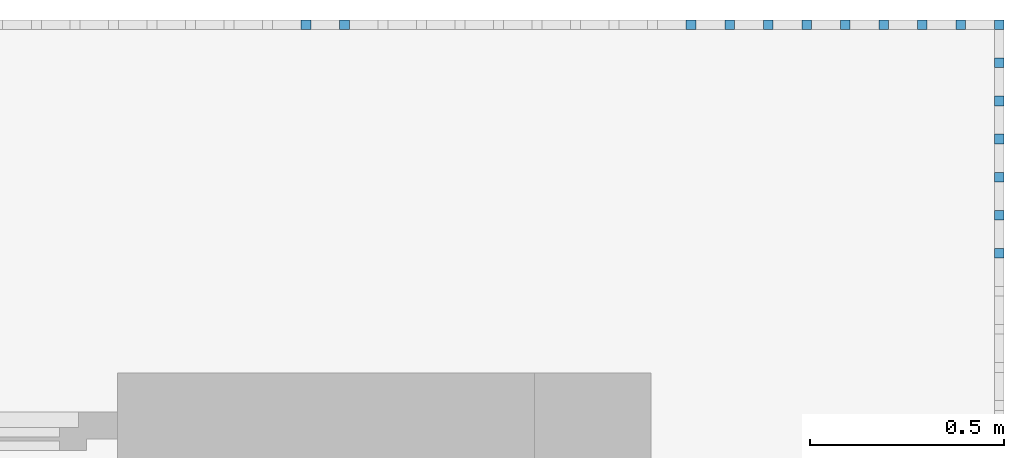
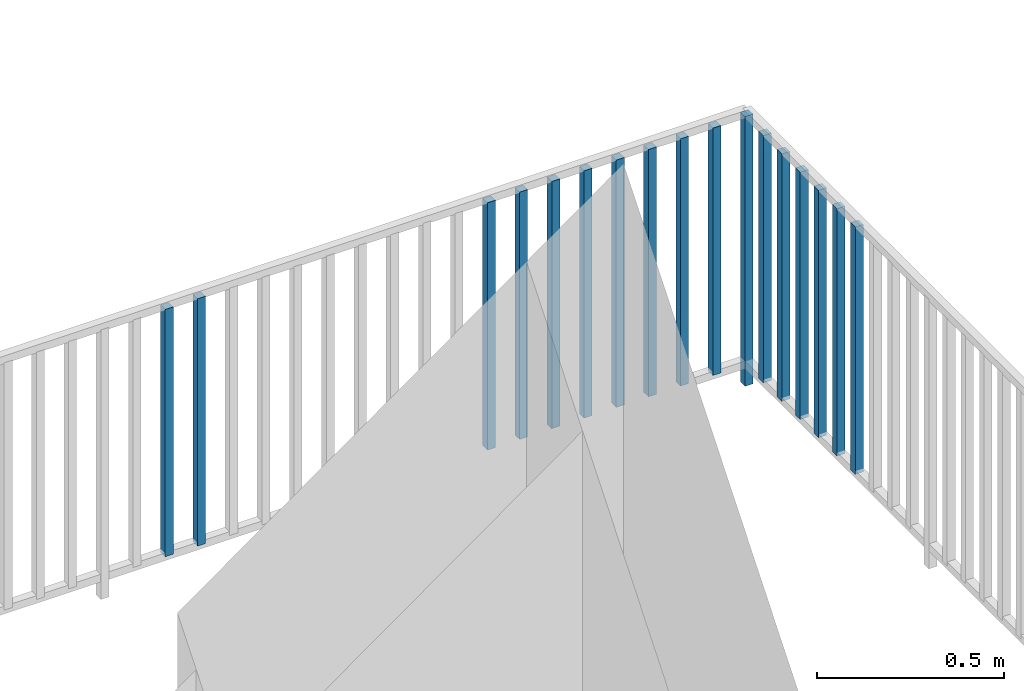
# One storey, part 54 of 54: 18 building element parts, 1 element without a shape of its own.
"""IFC4 building model written with IfcOpenShell, lengths in metres."""

from ifc_helpers import new_model, entity, si_unit, converted_unit, derived_unit, direction, frame, origin_with_axes, place, context, subcontext, project, spatial, polygons, material, type_object, element, aggregate, save


model = new_model("IFC4")

# Units and contexts
model_context = context("Model", 3, precision=1e-05, world=origin_with_axes(), true_north=direction((0.0, 1.0)))
body_context = subcontext(model_context, "Body", "Model", "MODEL_VIEW")
ifc_project = project(units=[si_unit("LENGTHUNIT", "METRE"), si_unit("AREAUNIT", "SQUARE_METRE"), si_unit("VOLUMEUNIT", "CUBIC_METRE"), converted_unit("PLANEANGLEUNIT", "DEGREE", entity("IfcPlaneAngleMeasure", 0.0174532925199), si_unit("PLANEANGLEUNIT", "RADIAN"), dimensions=[0, 0, 0, 0, 0, 0, 0]), converted_unit("TIMEUNIT", "Year", entity("IfcTimeMeasure", 31556926.0), si_unit("TIMEUNIT", "SECOND"), dimensions=[0, 0, 1, 0, 0, 0, 0]), si_unit("MASSUNIT", "GRAM", prefix="KILO"), si_unit("THERMODYNAMICTEMPERATUREUNIT", "DEGREE_CELSIUS"), si_unit("LUMINOUSINTENSITYUNIT", "LUMEN"), si_unit("ENERGYUNIT", "JOULE", prefix="MEGA"), derived_unit("THERMALCONDUCTANCEUNIT", [(si_unit("POWERUNIT", "WATT"), 1), (si_unit("LENGTHUNIT", "METRE"), -1), (si_unit("THERMODYNAMICTEMPERATUREUNIT", "KELVIN"), -1)]), derived_unit("SPECIFICHEATCAPACITYUNIT", [(si_unit("ENERGYUNIT", "JOULE"), 1), (si_unit("MASSUNIT", "GRAM", prefix="KILO"), -1), (si_unit("THERMODYNAMICTEMPERATUREUNIT", "KELVIN"), -1)]), derived_unit("MASSDENSITYUNIT", [(si_unit("MASSUNIT", "GRAM", prefix="KILO"), 1), (si_unit("VOLUMEUNIT", "CUBIC_METRE"), -1)])], contexts=[model_context])

# Site, building, storey, space
site_placement = place(None, origin_with_axes())
site = spatial("IfcSite", under=ifc_project, at=site_placement, CompositionType="ELEMENT")
building_placement = place(site_placement, origin_with_axes())
building = spatial("IfcBuilding", under=site, at=building_placement, CompositionType="ELEMENT")
storey_placement = place(building_placement, frame((0.0, 0.0, 6.29), z_axis=(0.0, 0.0, 1.0), x_axis=(1.0, 0.0, 0.0)))
storey = spatial("IfcBuildingStorey", under=building, at=storey_placement, Name="2. Geschoss", CompositionType="ELEMENT", Elevation=6.29)
space_placement = place(storey_placement, frame((10.2378006196, 9.82118769833, 0.0), z_axis=(0.0, 0.0, 1.0), x_axis=(-1.0, 0.0, 0.0)))
space = spatial("IfcSpace", under=storey, at=space_placement, CompositionType="ELEMENT", PredefinedType="EXTERNAL")

# Railing, building element parts
railing_type = type_object("IfcRailingType", PredefinedType="NOTDEFINED")
railing_placement = place(space_placement, frame((0.0, -7.06315681498e-08, 0.0), z_axis=(0.0, 0.0, 1.0), x_axis=(-1.0, 0.0, 0.0)))
railing = element("IfcRailing", 1, at=railing_placement, inside=space, type_object=railing_type, PredefinedType="NOTDEFINED")
ifc_material = material()
building_element_part_1_placement = place(railing_placement, origin_with_axes())
building_element_part_1 = element("IfcBuildingElementPart", 2, at=building_element_part_1_placement, material=ifc_material, PredefinedType="NOTDEFINED", context=body_context, shape_type="Tessellation", body=[
    polygons([(-0.0125, 0.0125, 0.0), (-0.0125, -0.0125, 0.0), (-0.0125, -0.0125, 0.88), (-0.0125, 0.0125, 0.88), (0.0125, 0.0125, 0.0), (0.0125, -0.0125, 0.0), (0.0125, -0.0125, 0.88), (0.0125, 0.0125, 0.88)], [[[1, 2, 3, 4]], [[1, 5, 6, 2]], [[2, 6, 7, 3]], [[4, 3, 7, 8]], [[5, 1, 4, 8]], [[6, 5, 8, 7]]], closed=True),
])
building_element_part_2_placement = place(railing_placement, origin_with_axes())
building_element_part_2 = element("IfcBuildingElementPart", 3, at=building_element_part_2_placement, material=ifc_material, PredefinedType="NOTDEFINED", context=body_context, shape_type="Tessellation", body=[
    polygons([(0.0125, 0.0125, 0.0), (-0.0125, 0.0125, 0.0), (-0.0125, 0.0125, 0.88), (0.0125, 0.0125, 0.88), (0.0125, -0.0125, 0.0), (-0.0125, -0.0125, 0.0), (-0.0125, -0.0125, 0.88), (0.0125, -0.0125, 0.88)], [[[1, 2, 3, 4]], [[1, 5, 6, 2]], [[2, 6, 7, 3]], [[4, 3, 7, 8]], [[5, 1, 4, 8]], [[6, 5, 8, 7]]], closed=True),
])
building_element_part_3_placement = place(railing_placement, origin_with_axes())
building_element_part_3 = element("IfcBuildingElementPart", 4, at=building_element_part_3_placement, material=ifc_material, PredefinedType="NOTDEFINED", context=body_context, shape_type="Tessellation", body=[
    polygons([(-0.11197826087, 0.0125, 0.07), (-0.11197826087, -0.0125, 0.07), (-0.11197826087, -0.0125, 0.8775), (-0.11197826087, 0.0125, 0.8775), (-0.0869782608696, 0.0125, 0.07), (-0.0869782608696, -0.0125, 0.07), (-0.0869782608696, -0.0125, 0.8775), (-0.0869782608696, 0.0125, 0.8775)], [[[1, 2, 3, 4]], [[1, 5, 6, 2]], [[2, 6, 7, 3]], [[4, 3, 7, 8]], [[5, 1, 4, 8]], [[6, 5, 8, 7]]], closed=True),
])
building_element_part_4_placement = place(railing_placement, origin_with_axes())
building_element_part_4 = element("IfcBuildingElementPart", 5, at=building_element_part_4_placement, material=ifc_material, PredefinedType="NOTDEFINED", context=body_context, shape_type="Tessellation", body=[
    polygons([(-0.211456521739, 0.0125, 0.07), (-0.211456521739, -0.0125, 0.07), (-0.211456521739, -0.0125, 0.8775), (-0.211456521739, 0.0125, 0.8775), (-0.186456521739, 0.0125, 0.07), (-0.186456521739, -0.0125, 0.07), (-0.186456521739, -0.0125, 0.8775), (-0.186456521739, 0.0125, 0.8775)], [[[1, 2, 3, 4]], [[1, 5, 6, 2]], [[2, 6, 7, 3]], [[4, 3, 7, 8]], [[5, 1, 4, 8]], [[6, 5, 8, 7]]], closed=True),
])
building_element_part_5_placement = place(railing_placement, origin_with_axes())
building_element_part_5 = element("IfcBuildingElementPart", 6, at=building_element_part_5_placement, material=ifc_material, PredefinedType="NOTDEFINED", context=body_context, shape_type="Tessellation", body=[
    polygons([(-0.310934782609, 0.0125, 0.07), (-0.310934782609, -0.0125, 0.07), (-0.310934782609, -0.0125, 0.8775), (-0.310934782609, 0.0125, 0.8775), (-0.285934782609, 0.0125, 0.07), (-0.285934782609, -0.0125, 0.07), (-0.285934782609, -0.0125, 0.8775), (-0.285934782609, 0.0125, 0.8775)], [[[1, 2, 3, 4]], [[1, 5, 6, 2]], [[2, 6, 7, 3]], [[4, 3, 7, 8]], [[5, 1, 4, 8]], [[6, 5, 8, 7]]], closed=True),
])
building_element_part_6_placement = place(railing_placement, origin_with_axes())
building_element_part_6 = element("IfcBuildingElementPart", 7, at=building_element_part_6_placement, material=ifc_material, PredefinedType="NOTDEFINED", context=body_context, shape_type="Tessellation", body=[
    polygons([(-0.410413043478, 0.0125, 0.07), (-0.410413043478, -0.0125, 0.07), (-0.410413043478, -0.0125, 0.8775), (-0.410413043478, 0.0125, 0.8775), (-0.385413043478, 0.0125, 0.07), (-0.385413043478, -0.0125, 0.07), (-0.385413043478, -0.0125, 0.8775), (-0.385413043478, 0.0125, 0.8775)], [[[1, 2, 3, 4]], [[1, 5, 6, 2]], [[2, 6, 7, 3]], [[4, 3, 7, 8]], [[5, 1, 4, 8]], [[6, 5, 8, 7]]], closed=True),
])
building_element_part_7_placement = place(railing_placement, origin_with_axes())
building_element_part_7 = element("IfcBuildingElementPart", 8, at=building_element_part_7_placement, material=ifc_material, PredefinedType="NOTDEFINED", context=body_context, shape_type="Tessellation", body=[
    polygons([(-0.509891304348, 0.0125, 0.07), (-0.509891304348, -0.0125, 0.07), (-0.509891304348, -0.0125, 0.8775), (-0.509891304348, 0.0125, 0.8775), (-0.484891304348, 0.0125, 0.07), (-0.484891304348, -0.0125, 0.07), (-0.484891304348, -0.0125, 0.8775), (-0.484891304348, 0.0125, 0.8775)], [[[1, 2, 3, 4]], [[1, 5, 6, 2]], [[2, 6, 7, 3]], [[4, 3, 7, 8]], [[5, 1, 4, 8]], [[6, 5, 8, 7]]], closed=True),
])
building_element_part_8_placement = place(railing_placement, origin_with_axes())
building_element_part_8 = element("IfcBuildingElementPart", 9, at=building_element_part_8_placement, material=ifc_material, PredefinedType="NOTDEFINED", context=body_context, shape_type="Tessellation", body=[
    polygons([(-0.609369565217, 0.0125, 0.07), (-0.609369565217, -0.0125, 0.07), (-0.609369565217, -0.0125, 0.8775), (-0.609369565217, 0.0125, 0.8775), (-0.584369565217, 0.0125, 0.07), (-0.584369565217, -0.0125, 0.07), (-0.584369565217, -0.0125, 0.8775), (-0.584369565217, 0.0125, 0.8775)], [[[1, 2, 3, 4]], [[1, 5, 6, 2]], [[2, 6, 7, 3]], [[4, 3, 7, 8]], [[5, 1, 4, 8]], [[6, 5, 8, 7]]], closed=True),
])
building_element_part_9_placement = place(railing_placement, origin_with_axes())
building_element_part_9 = element("IfcBuildingElementPart", 10, at=building_element_part_9_placement, material=ifc_material, PredefinedType="NOTDEFINED", context=body_context, shape_type="Tessellation", body=[
    polygons([(-0.708847826087, 0.0125, 0.07), (-0.708847826087, -0.0125, 0.07), (-0.708847826087, -0.0125, 0.8775), (-0.708847826087, 0.0125, 0.8775), (-0.683847826087, 0.0125, 0.07), (-0.683847826087, -0.0125, 0.07), (-0.683847826087, -0.0125, 0.8775), (-0.683847826087, 0.0125, 0.8775)], [[[1, 2, 3, 4]], [[1, 5, 6, 2]], [[2, 6, 7, 3]], [[4, 3, 7, 8]], [[5, 1, 4, 8]], [[6, 5, 8, 7]]], closed=True),
])
building_element_part_10_placement = place(railing_placement, origin_with_axes())
building_element_part_10 = element("IfcBuildingElementPart", 11, at=building_element_part_10_placement, material=ifc_material, PredefinedType="NOTDEFINED", context=body_context, shape_type="Tessellation", body=[
    polygons([(-0.808326086957, 0.0125, 0.07), (-0.808326086957, -0.0125, 0.07), (-0.808326086957, -0.0125, 0.8775), (-0.808326086957, 0.0125, 0.8775), (-0.783326086957, 0.0125, 0.07), (-0.783326086957, -0.0125, 0.07), (-0.783326086957, -0.0125, 0.8775), (-0.783326086957, 0.0125, 0.8775)], [[[1, 2, 3, 4]], [[1, 5, 6, 2]], [[2, 6, 7, 3]], [[4, 3, 7, 8]], [[5, 1, 4, 8]], [[6, 5, 8, 7]]], closed=True),
])
building_element_part_11_placement = place(railing_placement, origin_with_axes())
building_element_part_11 = element("IfcBuildingElementPart", 12, at=building_element_part_11_placement, material=ifc_material, PredefinedType="NOTDEFINED", context=body_context, shape_type="Tessellation", body=[
    polygons([(-1.70363043478, 0.0125, 0.07), (-1.70363043478, -0.0125, 0.07), (-1.70363043478, -0.0125, 0.8775), (-1.70363043478, 0.0125, 0.8775), (-1.67863043478, 0.0125, 0.07), (-1.67863043478, -0.0125, 0.07), (-1.67863043478, -0.0125, 0.8775), (-1.67863043478, 0.0125, 0.8775)], [[[1, 2, 3, 4]], [[1, 5, 6, 2]], [[2, 6, 7, 3]], [[4, 3, 7, 8]], [[5, 1, 4, 8]], [[6, 5, 8, 7]]], closed=True),
])
building_element_part_12_placement = place(railing_placement, origin_with_axes())
building_element_part_12 = element("IfcBuildingElementPart", 13, at=building_element_part_12_placement, material=ifc_material, PredefinedType="NOTDEFINED", context=body_context, shape_type="Tessellation", body=[
    polygons([(-1.80310869565, 0.0125, 0.07), (-1.80310869565, -0.0125, 0.07), (-1.80310869565, -0.0125, 0.8775), (-1.80310869565, 0.0125, 0.8775), (-1.77810869565, 0.0125, 0.07), (-1.77810869565, -0.0125, 0.07), (-1.77810869565, -0.0125, 0.8775), (-1.77810869565, 0.0125, 0.8775)], [[[1, 2, 3, 4]], [[1, 5, 6, 2]], [[2, 6, 7, 3]], [[4, 3, 7, 8]], [[5, 1, 4, 8]], [[6, 5, 8, 7]]], closed=True),
])
building_element_part_13_placement = place(railing_placement, origin_with_axes())
building_element_part_13 = element("IfcBuildingElementPart", 14, at=building_element_part_13_placement, material=ifc_material, PredefinedType="NOTDEFINED", context=body_context, shape_type="Tessellation", body=[
    polygons([(0.0125, -0.5775, 0.07), (-0.0125, -0.5775, 0.07), (-0.0125, -0.5775, 0.8775), (0.0125, -0.5775, 0.8775), (0.0125, -0.6025, 0.07), (-0.0125, -0.6025, 0.07), (-0.0125, -0.6025, 0.8775), (0.0125, -0.6025, 0.8775)], [[[1, 2, 3, 4]], [[1, 5, 6, 2]], [[2, 6, 7, 3]], [[4, 3, 7, 8]], [[5, 1, 4, 8]], [[6, 5, 8, 7]]], closed=True),
])
building_element_part_14_placement = place(railing_placement, origin_with_axes())
building_element_part_14 = element("IfcBuildingElementPart", 15, at=building_element_part_14_placement, material=ifc_material, PredefinedType="NOTDEFINED", context=body_context, shape_type="Tessellation", body=[
    polygons([(0.0125, -0.479166666667, 0.07), (-0.0125, -0.479166666667, 0.07), (-0.0125, -0.479166666667, 0.8775), (0.0125, -0.479166666667, 0.8775), (0.0125, -0.504166666667, 0.07), (-0.0125, -0.504166666667, 0.07), (-0.0125, -0.504166666667, 0.8775), (0.0125, -0.504166666667, 0.8775)], [[[1, 2, 3, 4]], [[1, 5, 6, 2]], [[2, 6, 7, 3]], [[4, 3, 7, 8]], [[5, 1, 4, 8]], [[6, 5, 8, 7]]], closed=True),
])
building_element_part_15_placement = place(railing_placement, origin_with_axes())
building_element_part_15 = element("IfcBuildingElementPart", 16, at=building_element_part_15_placement, material=ifc_material, PredefinedType="NOTDEFINED", context=body_context, shape_type="Tessellation", body=[
    polygons([(0.0125, -0.380833333333, 0.07), (-0.0125, -0.380833333333, 0.07), (-0.0125, -0.380833333333, 0.8775), (0.0125, -0.380833333333, 0.8775), (0.0125, -0.405833333333, 0.07), (-0.0125, -0.405833333333, 0.07), (-0.0125, -0.405833333333, 0.8775), (0.0125, -0.405833333333, 0.8775)], [[[1, 2, 3, 4]], [[1, 5, 6, 2]], [[2, 6, 7, 3]], [[4, 3, 7, 8]], [[5, 1, 4, 8]], [[6, 5, 8, 7]]], closed=True),
])
building_element_part_16_placement = place(railing_placement, origin_with_axes())
building_element_part_16 = element("IfcBuildingElementPart", 17, at=building_element_part_16_placement, material=ifc_material, PredefinedType="NOTDEFINED", context=body_context, shape_type="Tessellation", body=[
    polygons([(0.0125, -0.2825, 0.07), (-0.0125, -0.2825, 0.07), (-0.0125, -0.2825, 0.8775), (0.0125, -0.2825, 0.8775), (0.0125, -0.3075, 0.07), (-0.0125, -0.3075, 0.07), (-0.0125, -0.3075, 0.8775), (0.0125, -0.3075, 0.8775)], [[[1, 2, 3, 4]], [[1, 5, 6, 2]], [[2, 6, 7, 3]], [[4, 3, 7, 8]], [[5, 1, 4, 8]], [[6, 5, 8, 7]]], closed=True),
])
building_element_part_17_placement = place(railing_placement, origin_with_axes())
building_element_part_17 = element("IfcBuildingElementPart", 18, at=building_element_part_17_placement, material=ifc_material, PredefinedType="NOTDEFINED", context=body_context, shape_type="Tessellation", body=[
    polygons([(0.0125, -0.184166666667, 0.07), (-0.0125, -0.184166666667, 0.07), (-0.0125, -0.184166666667, 0.8775), (0.0125, -0.184166666667, 0.8775), (0.0125, -0.209166666667, 0.07), (-0.0125, -0.209166666667, 0.07), (-0.0125, -0.209166666667, 0.8775), (0.0125, -0.209166666667, 0.8775)], [[[1, 2, 3, 4]], [[1, 5, 6, 2]], [[2, 6, 7, 3]], [[4, 3, 7, 8]], [[5, 1, 4, 8]], [[6, 5, 8, 7]]], closed=True),
])
building_element_part_18_placement = place(railing_placement, origin_with_axes())
building_element_part_18 = element("IfcBuildingElementPart", 19, at=building_element_part_18_placement, material=ifc_material, PredefinedType="NOTDEFINED", context=body_context, shape_type="Tessellation", body=[
    polygons([(0.0125, -0.0858333333333, 0.07), (-0.0125, -0.0858333333333, 0.07), (-0.0125, -0.0858333333333, 0.8775), (0.0125, -0.0858333333333, 0.8775), (0.0125, -0.110833333333, 0.07), (-0.0125, -0.110833333333, 0.07), (-0.0125, -0.110833333333, 0.8775), (0.0125, -0.110833333333, 0.8775)], [[[1, 2, 3, 4]], [[1, 5, 6, 2]], [[2, 6, 7, 3]], [[4, 3, 7, 8]], [[5, 1, 4, 8]], [[6, 5, 8, 7]]], closed=True),
])
aggregate(railing, [building_element_part_1, building_element_part_2, building_element_part_3, building_element_part_4, building_element_part_5, building_element_part_6, building_element_part_7, building_element_part_8, building_element_part_9, building_element_part_10, building_element_part_11, building_element_part_12, building_element_part_13, building_element_part_14, building_element_part_15, building_element_part_16, building_element_part_17, building_element_part_18])

save(model, "model.ifc")
